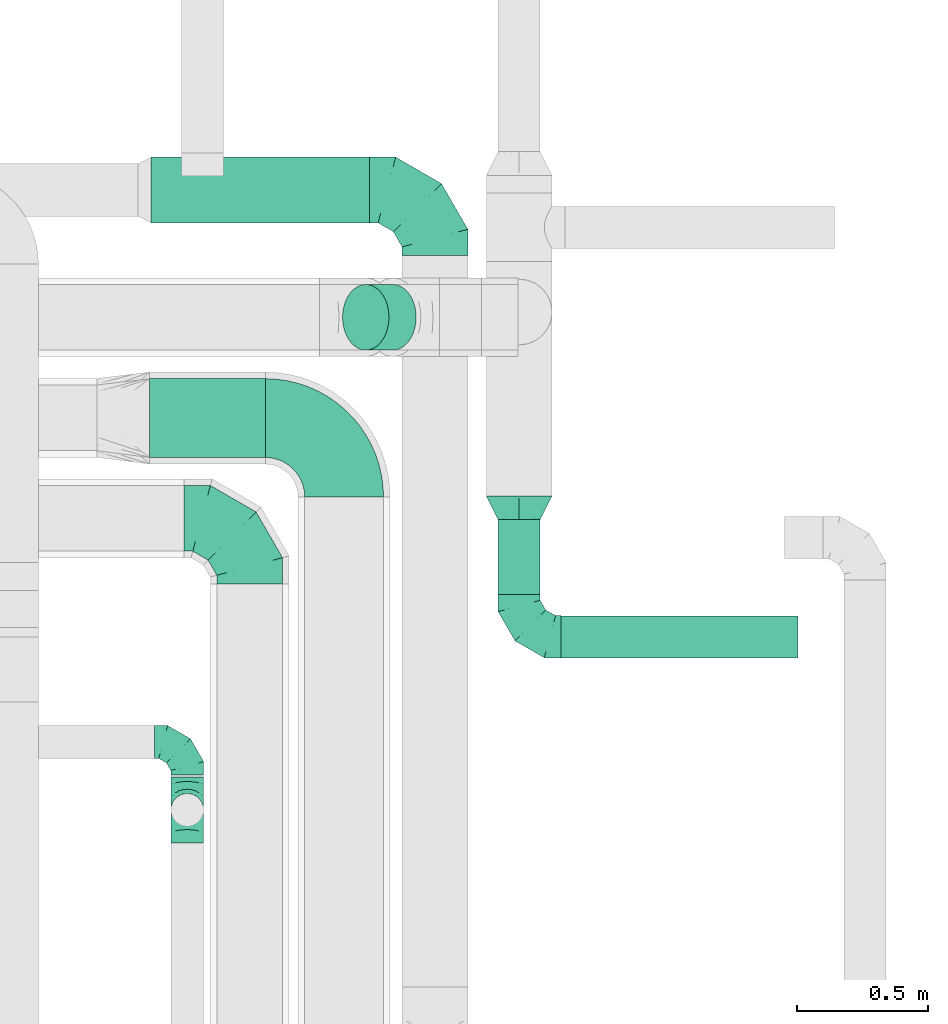
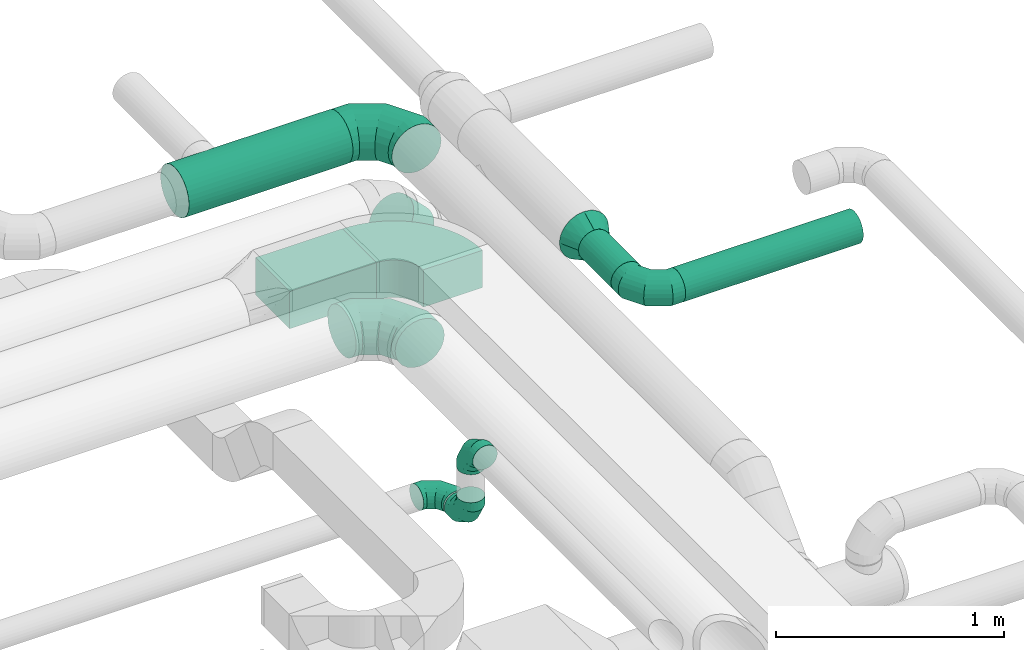
# One storey, part 73 of 92: 8 flow fittings, 5 flow segments.
"""IFC2X3 building model written with IfcOpenShell, lengths in millimetres."""

from ifc_helpers import new_model, entity, si_unit, converted_unit, derived_unit, direction, frame, frame_2d, origin, origin_2d_with_axis, place, context, subcontext, project, spatial, polyline, circle_curve, parameter, trimmed, segment, composite_curve, rectangle, circle, outline, extrude, faceted_brep, source, transform, mapped, material, type_object, type_shapes, element, save


model = new_model("IFC2X3")

# Units and contexts
model_context = context("Model", 3, precision=0.01, world=origin(), true_north=direction((6.12303176911189e-17, 1.0)))
body_context = subcontext(model_context, "Body", "Model", "MODEL_VIEW")
ifc_project = project(units=[si_unit("LENGTHUNIT", "METRE", prefix="MILLI"), si_unit("AREAUNIT", "SQUARE_METRE"), si_unit("VOLUMEUNIT", "CUBIC_METRE"), converted_unit("PLANEANGLEUNIT", "DEGREE", entity("IfcRatioMeasure", 0.0174532925199433), si_unit("PLANEANGLEUNIT", "RADIAN"), dimensions=[0, 0, 0, 0, 0, 0, 0]), si_unit("MASSUNIT", "GRAM", prefix="KILO"), derived_unit("MASSDENSITYUNIT", [(si_unit("MASSUNIT", "GRAM", prefix="KILO"), 1), (si_unit("LENGTHUNIT", "METRE"), -3)]), derived_unit("MOMENTOFINERTIAUNIT", [(si_unit("LENGTHUNIT", "METRE"), 4)]), si_unit("TIMEUNIT", "SECOND"), si_unit("FREQUENCYUNIT", "HERTZ"), si_unit("THERMODYNAMICTEMPERATUREUNIT", "DEGREE_CELSIUS"), derived_unit("THERMALTRANSMITTANCEUNIT", [(si_unit("MASSUNIT", "GRAM", prefix="KILO"), 1), (si_unit("THERMODYNAMICTEMPERATUREUNIT", "KELVIN"), -1), (si_unit("TIMEUNIT", "SECOND"), -3)]), derived_unit("VOLUMETRICFLOWRATEUNIT", [(si_unit("LENGTHUNIT", "METRE"), 3), (si_unit("TIMEUNIT", "SECOND"), -1)]), derived_unit("MASSFLOWRATEUNIT", [(si_unit("MASSUNIT", "GRAM", prefix="KILO"), 1), (si_unit("TIMEUNIT", "SECOND"), -1)]), derived_unit("ROTATIONALFREQUENCYUNIT", [(si_unit("TIMEUNIT", "SECOND"), -1)]), si_unit("ELECTRICCURRENTUNIT", "AMPERE"), si_unit("ELECTRICVOLTAGEUNIT", "VOLT"), si_unit("POWERUNIT", "WATT"), si_unit("FORCEUNIT", "NEWTON", prefix="KILO"), si_unit("ILLUMINANCEUNIT", "LUX"), si_unit("LUMINOUSFLUXUNIT", "LUMEN"), si_unit("LUMINOUSINTENSITYUNIT", "CANDELA"), derived_unit("USERDEFINED", [(si_unit("MASSUNIT", "GRAM", prefix="KILO"), -1), (si_unit("LENGTHUNIT", "METRE"), -2), (si_unit("TIMEUNIT", "SECOND"), 3), (si_unit("LUMINOUSFLUXUNIT", "LUMEN"), 1)]), derived_unit("LINEARVELOCITYUNIT", [(si_unit("LENGTHUNIT", "METRE"), 1), (si_unit("TIMEUNIT", "SECOND"), -1)]), si_unit("PRESSUREUNIT", "PASCAL"), derived_unit("USERDEFINED", [(si_unit("LENGTHUNIT", "METRE"), -2), (si_unit("MASSUNIT", "GRAM", prefix="KILO"), 1), (si_unit("TIMEUNIT", "SECOND"), -2)]), derived_unit("LINEARFORCEUNIT", [(si_unit("MASSUNIT", "GRAM", prefix="KILO"), 1), (si_unit("LENGTHUNIT", "METRE"), 1), (si_unit("TIMEUNIT", "SECOND"), -2), (si_unit("LENGTHUNIT", "METRE"), -1)]), derived_unit("PLANARFORCEUNIT", [(si_unit("MASSUNIT", "GRAM", prefix="KILO"), 1), (si_unit("LENGTHUNIT", "METRE"), 1), (si_unit("TIMEUNIT", "SECOND"), -2), (si_unit("LENGTHUNIT", "METRE"), -2)])], contexts=[model_context])

# Site, building, storey
site_placement = place(None, origin())
site = spatial("IfcSite", under=ifc_project, at=site_placement, CompositionType="ELEMENT")
building_placement = place(site_placement, origin())
building = spatial("IfcBuilding", under=site, at=building_placement, CompositionType="ELEMENT")
storey_placement = place(building_placement, frame((0.0, 0.0, 4200.0)))
storey = spatial("IfcBuildingStorey", under=building, at=storey_placement, CompositionType="ELEMENT", Elevation=4200.0)

# Flow segments
duct_segment_type_1 = type_object("IfcDuctSegmentType", PredefinedType="NOTDEFINED")
flow_segment_1_placement = place(storey_placement, frame((60704.33, 15188.51, 3200.0)))
element("IfcFlowSegment", 1, at=flow_segment_1_placement, inside=storey, type_object=duct_segment_type_1, context=body_context, shape_type="SweptSolid", body=[
    extrude(rectangle(XDim=440.000000000013, YDim=300.000000000001, at=origin_2d_with_axis()), frame((220.0, 150.0, 0.0), z_axis=(0.0, 0.0, 1.0), x_axis=(-1.0, 0.0, 0.0)), (0.0, 0.0, 1.0), 200.0),
])
duct_segment_type_2 = type_object("IfcDuctSegmentType", PredefinedType="NOTDEFINED")
flow_segment_2_placement = place(storey_placement, frame((60710.0, 16079.62, 3193.4)))
element("IfcFlowSegment", 2, at=flow_segment_2_placement, inside=storey, type_object=duct_segment_type_2, context=body_context, shape_type="SweptSolid", body=[
    extrude(circle(Radius=125.0, at=origin_2d_with_axis()), frame((0.0, 126.6, 126.6), z_axis=(1.0, 0.0, 0.0), x_axis=(0.0, 1.0, 0.0)), (0.0, 0.0, 1.0), 830.000000000071),
])
flow_segment_3_placement = place(storey_placement, frame((61436.58, 15595.41, 2983.24)))
element("IfcFlowSegment", 3, at=flow_segment_3_placement, inside=storey, type_object=duct_segment_type_2, context=body_context, shape_type="SweptSolid", body=[
    extrude(circle(Radius=125.0, at=origin_2d_with_axis()), frame((193.54, 126.6, 89.98), z_axis=(-0.707106445676234, 0.0, 0.707107116696702), x_axis=(0.0, -1.0, 0.0)), (0.0, 0.0, 1.0), 146.446302678895),
])
duct_segment_type_3 = type_object("IfcDuctSegmentType", PredefinedType="NOTDEFINED")
flow_segment_4_placement = place(storey_placement, frame((62028.4, 14666.74, 3218.4)))
element("IfcFlowSegment", 4, at=flow_segment_4_placement, inside=storey, type_object=duct_segment_type_3, context=body_context, shape_type="SweptSolid", body=[
    extrude(circle(Radius=80.0, at=origin_2d_with_axis()), frame((81.6, 0.0, 81.6), z_axis=(0.0, 1.0, 0.0), x_axis=(1.0, 0.0, 0.0)), (0.0, 0.0, 1.0), 285.234298504728),
])
flow_segment_5_placement = place(storey_placement, frame((62270.0, 14425.15, 3218.4)))
element("IfcFlowSegment", 5, at=flow_segment_5_placement, inside=storey, type_object=duct_segment_type_3, context=body_context, shape_type="SweptSolid", body=[
    extrude(circle(Radius=80.0, at=origin_2d_with_axis()), frame((0.0, 81.6, 81.6), z_axis=(1.0, 0.0, 0.0), x_axis=(0.0, -1.0, 0.0)), (0.0, 0.0, 1.0), 900.000000000012),
])

# Flow fittings
ifc_material = material()
duct_fitting_type_1 = type_object("IfcDuctFittingType", PredefinedType="NOTDEFINED", material=ifc_material)
shared_shape_1 = source(origin(), body_context, "Body", "Brep", [
    faceted_brep([(-160.0, 0.0, -80.0), (-160.0, -20.71, -77.27), (-160.0, -40.0, -69.28), (-160.0, -56.57, -56.57), (-160.0, -69.28, -40.0), (-160.0, -77.27, -20.71), (-160.0, -80.0, 0.0), (-160.0, -77.27, 20.71), (-160.0, -69.28, 40.0), (-160.0, -56.57, 56.57), (-160.0, -40.0, 69.28), (-160.0, -20.71, 77.27), (-160.0, 0.0, 80.0), (-160.0, 20.71, 77.27), (-160.0, 40.0, 69.28), (-160.0, 56.57, 56.57), (-160.0, 69.28, 40.0), (-160.0, 77.27, 20.71), (-160.0, 80.0, 0.0), (-160.0, 77.27, -20.71), (-160.0, 69.28, -40.0), (-160.0, 56.57, -56.57), (-160.0, 40.0, -69.28), (-160.0, 20.71, -77.27), (-122.68, 20.71, 77.27), (-127.85, 40.0, 69.28), (-117.13, 0.0, 80.0), (-132.29, 56.57, 56.57), (-137.83, 77.27, 20.71), (-138.56, 80.0, 0.0), (-135.69, 69.28, 40.0), (-135.69, 69.28, -40.0), (-132.29, 56.57, -56.57), (-137.83, 77.27, -20.71), (-122.68, 20.71, -77.27), (-117.13, 0.0, -80.0), (-127.85, 40.0, -69.28), (-111.58, -20.71, -77.27), (-106.41, -40.0, -69.28), (-101.97, -56.57, -56.57), (-98.56, -69.28, -40.0), (-96.42, -77.27, -20.71), (-95.69, -80.0, 0.0), (-96.42, -77.27, 20.71), (-98.56, -69.28, 40.0), (-101.97, -56.57, 56.57), (-106.41, -40.0, 69.28), (-111.58, -20.71, 77.27), (-58.03, 58.03, 77.27), (-72.15, 72.15, 69.28), (-42.87, 42.87, 80.0), (-84.28, 84.28, 56.57), (-93.59, 93.59, 40.0), (-99.44, 99.44, 20.71), (-101.44, 101.44, 0.0), (-99.44, 99.44, -20.71), (-93.59, 93.59, -40.0), (-84.28, 84.28, -56.57), (-58.03, 58.03, -77.27), (-42.87, 42.87, -80.0), (-72.15, 72.15, -69.28), (-27.71, 27.71, -77.27), (-13.59, 13.59, -69.28), (-1.46, 1.46, -56.57), (7.85, -7.85, -40.0), (13.7, -13.7, -20.71), (15.69, -15.69, 0.0), (13.7, -13.7, 20.71), (7.85, -7.85, 40.0), (-1.46, 1.46, 56.57), (-13.59, 13.59, 69.28), (-27.71, 27.71, 77.27), (-20.71, 122.68, 77.27), (-40.0, 127.85, 69.28), (0.0, 117.13, 80.0), (-56.57, 132.29, 56.57), (-69.28, 135.69, 40.0), (-77.27, 137.83, 20.71), (-80.0, 138.56, 0.0), (-77.27, 137.83, -20.71), (-69.28, 135.69, -40.0), (-56.57, 132.29, -56.57), (-20.71, 122.68, -77.27), (0.0, 117.13, -80.0), (-40.0, 127.85, -69.28), (20.71, 111.58, -77.27), (40.0, 106.41, -69.28), (56.57, 101.97, -56.57), (69.28, 98.56, -40.0), (77.27, 96.42, -20.71), (80.0, 95.69, 0.0), (77.27, 96.42, 20.71), (69.28, 98.56, 40.0), (56.57, 101.97, 56.57), (40.0, 106.41, 69.28), (20.71, 111.58, 77.27), (-20.71, 160.0, -77.27), (-40.0, 160.0, -69.28), (-56.57, 160.0, -56.57), (-69.28, 160.0, -40.0), (-77.27, 160.0, -20.71), (-80.0, 160.0, 0.0), (-77.27, 160.0, 20.71), (-69.28, 160.0, 40.0), (-56.57, 160.0, 56.57), (-40.0, 160.0, 69.28), (-20.71, 160.0, 77.27), (0.0, 160.0, 80.0), (20.71, 160.0, 77.27), (40.0, 160.0, 69.28), (56.57, 160.0, 56.57), (69.28, 160.0, 40.0), (77.27, 160.0, 20.71), (80.0, 160.0, 0.0), (77.27, 160.0, -20.71), (69.28, 160.0, -40.0), (56.57, 160.0, -56.57), (40.0, 160.0, -69.28), (20.71, 160.0, -77.27), (0.0, 160.0, -80.0)], [[[0, 1, 2, 3, 4, 5, 6, 7, 8, 9, 10, 11, 12, 13, 14, 15, 16, 17, 18, 19, 20, 21, 22, 23]], [[24, 25, 14, 13]], [[26, 24, 13, 12]], [[14, 25, 27, 15]], [[28, 29, 18, 17]], [[30, 28, 17, 16]], [[15, 27, 30, 16]], [[20, 31, 32, 21]], [[33, 31, 20, 19]], [[18, 29, 33, 19]], [[34, 35, 0, 23]], [[36, 34, 23, 22]], [[32, 36, 22, 21]], [[1, 0, 35, 37]], [[2, 1, 37, 38]], [[3, 2, 38, 39]], [[5, 4, 40, 41]], [[6, 5, 41, 42]], [[39, 40, 4, 3]], [[6, 42, 43, 7]], [[7, 43, 44, 8]], [[8, 44, 45, 9]], [[9, 45, 46, 10]], [[10, 46, 47, 11]], [[26, 12, 11, 47]], [[48, 49, 25, 24]], [[50, 48, 24, 26]], [[27, 25, 49, 51]], [[52, 53, 28, 30]], [[51, 52, 30, 27]], [[29, 28, 53, 54]], [[55, 56, 31, 33]], [[54, 55, 33, 29]], [[32, 31, 56, 57]], [[58, 59, 35, 34]], [[60, 58, 34, 36]], [[57, 60, 36, 32]], [[37, 35, 59, 61]], [[38, 37, 61, 62]], [[39, 38, 62, 63]], [[41, 40, 64, 65]], [[42, 41, 65, 66]], [[63, 64, 40, 39]], [[43, 42, 66, 67]], [[44, 43, 67, 68]], [[68, 69, 45, 44]], [[46, 45, 69, 70]], [[47, 46, 70, 71]], [[26, 47, 71, 50]], [[72, 73, 49, 48]], [[74, 72, 48, 50]], [[51, 49, 73, 75]], [[76, 77, 53, 52]], [[75, 76, 52, 51]], [[54, 53, 77, 78]], [[79, 80, 56, 55]], [[78, 79, 55, 54]], [[57, 56, 80, 81]], [[82, 83, 59, 58]], [[84, 82, 58, 60]], [[81, 84, 60, 57]], [[61, 59, 83, 85]], [[62, 61, 85, 86]], [[63, 62, 86, 87]], [[65, 64, 88, 89]], [[66, 65, 89, 90]], [[87, 88, 64, 63]], [[67, 66, 90, 91]], [[68, 67, 91, 92]], [[92, 93, 69, 68]], [[70, 69, 93, 94]], [[71, 70, 94, 95]], [[50, 71, 95, 74]], [[96, 97, 98, 99, 100, 101, 102, 103, 104, 105, 106, 107, 108, 109, 110, 111, 112, 113, 114, 115, 116, 117, 118, 119]], [[72, 74, 107, 106]], [[73, 72, 106, 105]], [[75, 73, 105, 104]], [[77, 76, 103, 102]], [[78, 77, 102, 101]], [[75, 104, 103, 76]], [[78, 101, 100, 79]], [[79, 100, 99, 80]], [[80, 99, 98, 81]], [[84, 97, 96, 82]], [[82, 96, 119, 83]], [[84, 81, 98, 97]], [[118, 117, 86, 85]], [[119, 118, 85, 83]], [[116, 87, 86, 117]], [[88, 115, 114, 89]], [[89, 114, 113, 90]], [[115, 88, 87, 116]], [[112, 111, 92, 91]], [[113, 112, 91, 90]], [[111, 110, 93, 92]], [[95, 94, 109, 108]], [[74, 95, 108, 107]], [[110, 109, 94, 93]]]),
])
type_shapes(duct_fitting_type_1, [shared_shape_1])
flow_fitting_1_placement = place(storey_placement, frame((62110.0, 14506.74, 3300.0), z_axis=(0.0, 0.0, 1.0), x_axis=(0.0, -1.0, 0.0)))
element("IfcFlowFitting", 6, at=flow_fitting_1_placement, inside=storey, type_object=duct_fitting_type_1, material=ifc_material, context=body_context, shape_type="MappedRepresentation", body=[
    mapped(shared_shape_1, transform((0.0, 0.0, 0.0), scale=1.0)),
])
duct_fitting_type_2 = type_object("IfcDuctFittingType", PredefinedType="NOTDEFINED", material=ifc_material)
shared_shape_2 = source(origin(), body_context, "Body", "Brep", [
    faceted_brep([(-250.0, 0.0, -125.0), (-250.0, -32.35, -120.74), (-250.0, -62.5, -108.25), (-250.0, -88.39, -88.39), (-250.0, -108.25, -62.5), (-250.0, -120.74, -32.35), (-250.0, -125.0, 0.0), (-250.0, -120.74, 32.35), (-250.0, -108.25, 62.5), (-250.0, -88.39, 88.39), (-250.0, -62.5, 108.25), (-250.0, -32.35, 120.74), (-250.0, 0.0, 125.0), (-250.0, 32.35, 120.74), (-250.0, 62.5, 108.25), (-250.0, 88.39, 88.39), (-250.0, 108.25, 62.5), (-250.0, 120.74, 32.35), (-250.0, 125.0, 0.0), (-250.0, 120.74, -32.35), (-250.0, 108.25, -62.5), (-250.0, 88.39, -88.39), (-250.0, 62.5, -108.25), (-250.0, 32.35, -120.74), (-191.68, 32.35, 120.74), (-199.76, 62.5, 108.25), (-183.01, 0.0, 125.0), (-206.7, 88.39, 88.39), (-215.37, 120.74, 32.35), (-216.51, 125.0, 0.0), (-212.02, 108.25, 62.5), (-212.02, 108.25, -62.5), (-206.7, 88.39, -88.39), (-215.37, 120.74, -32.35), (-191.68, 32.35, -120.74), (-183.01, 0.0, -125.0), (-199.76, 62.5, -108.25), (-174.34, -32.35, -120.74), (-166.27, -62.5, -108.25), (-159.33, -88.39, -88.39), (-154.01, -108.25, -62.5), (-150.66, -120.74, -32.35), (-149.52, -125.0, 0.0), (-150.66, -120.74, 32.35), (-154.01, -108.25, 62.5), (-159.33, -88.39, 88.39), (-166.27, -62.5, 108.25), (-174.34, -32.35, 120.74), (-90.67, 90.67, 120.74), (-112.74, 112.74, 108.25), (-66.99, 66.99, 125.0), (-131.69, 131.69, 88.39), (-146.23, 146.23, 62.5), (-155.38, 155.38, 32.35), (-158.49, 158.49, 0.0), (-155.38, 155.38, -32.35), (-146.23, 146.23, -62.5), (-131.69, 131.69, -88.39), (-90.67, 90.67, -120.74), (-66.99, 66.99, -125.0), (-112.74, 112.74, -108.25), (-43.3, 43.3, -120.74), (-21.23, 21.23, -108.25), (-2.28, 2.28, -88.39), (12.26, -12.26, -62.5), (21.4, -21.4, -32.35), (24.52, -24.52, 0.0), (21.4, -21.4, 32.35), (12.26, -12.26, 62.5), (-2.28, 2.28, 88.39), (-21.23, 21.23, 108.25), (-43.3, 43.3, 120.74), (-32.35, 191.68, 120.74), (-62.5, 199.76, 108.25), (0.0, 183.01, 125.0), (-88.39, 206.7, 88.39), (-108.25, 212.02, 62.5), (-120.74, 215.37, 32.35), (-125.0, 216.51, 0.0), (-120.74, 215.37, -32.35), (-108.25, 212.02, -62.5), (-88.39, 206.7, -88.39), (-32.35, 191.68, -120.74), (0.0, 183.01, -125.0), (-62.5, 199.76, -108.25), (32.35, 174.34, -120.74), (62.5, 166.27, -108.25), (88.39, 159.33, -88.39), (108.25, 154.01, -62.5), (120.74, 150.66, -32.35), (125.0, 149.52, 0.0), (120.74, 150.66, 32.35), (108.25, 154.01, 62.5), (88.39, 159.33, 88.39), (62.5, 166.27, 108.25), (32.35, 174.34, 120.74), (-32.35, 250.0, -120.74), (-62.5, 250.0, -108.25), (-88.39, 250.0, -88.39), (-108.25, 250.0, -62.5), (-120.74, 250.0, -32.35), (-125.0, 250.0, 0.0), (-120.74, 250.0, 32.35), (-108.25, 250.0, 62.5), (-88.39, 250.0, 88.39), (-62.5, 250.0, 108.25), (-32.35, 250.0, 120.74), (0.0, 250.0, 125.0), (32.35, 250.0, 120.74), (62.5, 250.0, 108.25), (88.39, 250.0, 88.39), (108.25, 250.0, 62.5), (120.74, 250.0, 32.35), (125.0, 250.0, 0.0), (120.74, 250.0, -32.35), (108.25, 250.0, -62.5), (88.39, 250.0, -88.39), (62.5, 250.0, -108.25), (32.35, 250.0, -120.74), (0.0, 250.0, -125.0)], [[[0, 1, 2, 3, 4, 5, 6, 7, 8, 9, 10, 11, 12, 13, 14, 15, 16, 17, 18, 19, 20, 21, 22, 23]], [[24, 25, 14, 13]], [[26, 24, 13, 12]], [[14, 25, 27, 15]], [[28, 29, 18, 17]], [[30, 28, 17, 16]], [[15, 27, 30, 16]], [[20, 31, 32, 21]], [[33, 31, 20, 19]], [[18, 29, 33, 19]], [[34, 35, 0, 23]], [[36, 34, 23, 22]], [[21, 32, 36, 22]], [[1, 0, 35, 37]], [[2, 1, 37, 38]], [[38, 39, 3, 2]], [[5, 4, 40, 41]], [[6, 5, 41, 42]], [[39, 40, 4, 3]], [[6, 42, 43, 7]], [[7, 43, 44, 8]], [[8, 44, 45, 9]], [[9, 45, 46, 10]], [[10, 46, 47, 11]], [[26, 12, 11, 47]], [[48, 49, 25, 24]], [[50, 48, 24, 26]], [[27, 25, 49, 51]], [[52, 53, 28, 30]], [[51, 52, 30, 27]], [[29, 28, 53, 54]], [[55, 56, 31, 33]], [[54, 55, 33, 29]], [[32, 31, 56, 57]], [[58, 59, 35, 34]], [[60, 58, 34, 36]], [[57, 60, 36, 32]], [[37, 35, 59, 61]], [[38, 37, 61, 62]], [[39, 38, 62, 63]], [[41, 40, 64, 65]], [[42, 41, 65, 66]], [[63, 64, 40, 39]], [[43, 42, 66, 67]], [[44, 43, 67, 68]], [[68, 69, 45, 44]], [[46, 45, 69, 70]], [[47, 46, 70, 71]], [[26, 47, 71, 50]], [[72, 73, 49, 48]], [[74, 72, 48, 50]], [[51, 49, 73, 75]], [[76, 77, 53, 52]], [[75, 76, 52, 51]], [[54, 53, 77, 78]], [[79, 80, 56, 55]], [[78, 79, 55, 54]], [[57, 56, 80, 81]], [[82, 83, 59, 58]], [[84, 82, 58, 60]], [[81, 84, 60, 57]], [[61, 59, 83, 85]], [[62, 61, 85, 86]], [[63, 62, 86, 87]], [[65, 64, 88, 89]], [[66, 65, 89, 90]], [[87, 88, 64, 63]], [[67, 66, 90, 91]], [[68, 67, 91, 92]], [[92, 93, 69, 68]], [[70, 69, 93, 94]], [[71, 70, 94, 95]], [[50, 71, 95, 74]], [[96, 97, 98, 99, 100, 101, 102, 103, 104, 105, 106, 107, 108, 109, 110, 111, 112, 113, 114, 115, 116, 117, 118, 119]], [[72, 74, 107, 106]], [[73, 72, 106, 105]], [[75, 73, 105, 104]], [[77, 76, 103, 102]], [[78, 77, 102, 101]], [[75, 104, 103, 76]], [[78, 101, 100, 79]], [[79, 100, 99, 80]], [[80, 99, 98, 81]], [[84, 97, 96, 82]], [[82, 96, 119, 83]], [[84, 81, 98, 97]], [[83, 119, 118, 85]], [[85, 118, 117, 86]], [[116, 87, 86, 117]], [[88, 115, 114, 89]], [[89, 114, 113, 90]], [[115, 88, 87, 116]], [[91, 90, 113, 112]], [[92, 91, 112, 111]], [[111, 110, 93, 92]], [[95, 94, 109, 108]], [[74, 95, 108, 107]], [[110, 109, 94, 93]]]),
])
type_shapes(duct_fitting_type_2, [shared_shape_2])
for number, where, z_axis, x_axis in (
    (7, (61790.0, 16206.22, 3320.0), (0.0, 0.0, 1.0), (0.0, 1.0, 0.0)),
    (8, (61085.0, 14957.0, 3282.5), (0.0, 0.0, 1.0), (0.0, 1.0, 0.0)),
):
    element("IfcFlowFitting", number, at=place(storey_placement, frame(where, z_axis=z_axis, x_axis=x_axis)), inside=storey, type_object=duct_fitting_type_2, material=ifc_material, context=body_context, shape_type="MappedRepresentation", body=[
        mapped(shared_shape_2, transform((0.0, 0.0, 0.0), scale=1.0)),
    ])
duct_fitting_type_3 = type_object("IfcDuctFittingType", PredefinedType="NOTDEFINED", material=ifc_material)
shared_shape_3 = source(origin(), body_context, "Body", "Brep", [
    faceted_brep([(-125.0, 0.0, -62.5), (-125.0, -16.18, -60.37), (-125.0, -31.25, -54.13), (-125.0, -44.19, -44.19), (-125.0, -54.13, -31.25), (-125.0, -60.37, -16.18), (-125.0, -62.5, 0.0), (-125.0, -60.37, 16.18), (-125.0, -54.13, 31.25), (-125.0, -44.19, 44.19), (-125.0, -31.25, 54.13), (-125.0, -16.18, 60.37), (-125.0, 0.0, 62.5), (-125.0, 16.18, 60.37), (-125.0, 31.25, 54.13), (-125.0, 44.19, 44.19), (-125.0, 54.13, 31.25), (-125.0, 60.37, 16.18), (-125.0, 62.5, 0.0), (-125.0, 60.37, -16.18), (-125.0, 54.13, -31.25), (-125.0, 44.19, -44.19), (-125.0, 31.25, -54.13), (-125.0, 16.18, -60.37), (-95.84, 16.18, 60.37), (-99.88, 31.25, 54.13), (-91.51, 0.0, 62.5), (-103.35, 44.19, 44.19), (-107.68, 60.37, 16.18), (-108.25, 62.5, 0.0), (-106.01, 54.13, 31.25), (-106.01, 54.13, -31.25), (-103.35, 44.19, -44.19), (-107.68, 60.37, -16.18), (-95.84, 16.18, -60.37), (-91.51, 0.0, -62.5), (-99.88, 31.25, -54.13), (-87.17, -16.18, -60.37), (-83.13, -31.25, -54.13), (-79.66, -44.19, -44.19), (-77.0, -54.13, -31.25), (-75.33, -60.37, -16.18), (-74.76, -62.5, 0.0), (-75.33, -60.37, 16.18), (-77.0, -54.13, 31.25), (-79.66, -44.19, 44.19), (-83.13, -31.25, 54.13), (-87.17, -16.18, 60.37), (-45.34, 45.34, 60.37), (-56.37, 56.37, 54.13), (-33.49, 33.49, 62.5), (-65.85, 65.85, 44.19), (-73.12, 73.12, 31.25), (-77.69, 77.69, 16.18), (-79.25, 79.25, 0.0), (-77.69, 77.69, -16.18), (-73.12, 73.12, -31.25), (-65.85, 65.85, -44.19), (-45.34, 45.34, -60.37), (-33.49, 33.49, -62.5), (-56.37, 56.37, -54.13), (-21.65, 21.65, -60.37), (-10.62, 10.62, -54.13), (-1.14, 1.14, -44.19), (6.13, -6.13, -31.25), (10.7, -10.7, -16.18), (12.26, -12.26, 0.0), (10.7, -10.7, 16.18), (6.13, -6.13, 31.25), (-1.14, 1.14, 44.19), (-10.62, 10.62, 54.13), (-21.65, 21.65, 60.37), (-16.18, 95.84, 60.37), (-31.25, 99.88, 54.13), (0.0, 91.51, 62.5), (-44.19, 103.35, 44.19), (-54.13, 106.01, 31.25), (-60.37, 107.68, 16.18), (-62.5, 108.25, 0.0), (-60.37, 107.68, -16.18), (-54.13, 106.01, -31.25), (-44.19, 103.35, -44.19), (-16.18, 95.84, -60.37), (0.0, 91.51, -62.5), (-31.25, 99.88, -54.13), (16.18, 87.17, -60.37), (31.25, 83.13, -54.13), (44.19, 79.66, -44.19), (54.13, 77.0, -31.25), (60.37, 75.33, -16.18), (62.5, 74.76, 0.0), (60.37, 75.33, 16.18), (54.13, 77.0, 31.25), (44.19, 79.66, 44.19), (31.25, 83.13, 54.13), (16.18, 87.17, 60.37), (-16.18, 125.0, -60.37), (-31.25, 125.0, -54.13), (-44.19, 125.0, -44.19), (-54.13, 125.0, -31.25), (-60.37, 125.0, -16.18), (-62.5, 125.0, 0.0), (-60.37, 125.0, 16.18), (-54.13, 125.0, 31.25), (-44.19, 125.0, 44.19), (-31.25, 125.0, 54.13), (-16.18, 125.0, 60.37), (0.0, 125.0, 62.5), (16.18, 125.0, 60.37), (31.25, 125.0, 54.13), (44.19, 125.0, 44.19), (54.13, 125.0, 31.25), (60.37, 125.0, 16.18), (62.5, 125.0, 0.0), (60.37, 125.0, -16.18), (54.13, 125.0, -31.25), (44.19, 125.0, -44.19), (31.25, 125.0, -54.13), (16.18, 125.0, -60.37), (0.0, 125.0, -62.5)], [[[0, 1, 2, 3, 4, 5, 6, 7, 8, 9, 10, 11, 12, 13, 14, 15, 16, 17, 18, 19, 20, 21, 22, 23]], [[24, 25, 14, 13]], [[26, 24, 13, 12]], [[14, 25, 27, 15]], [[28, 29, 18, 17]], [[30, 28, 17, 16]], [[15, 27, 30, 16]], [[20, 31, 32, 21]], [[33, 31, 20, 19]], [[18, 29, 33, 19]], [[34, 35, 0, 23]], [[36, 34, 23, 22]], [[21, 32, 36, 22]], [[1, 0, 35, 37]], [[2, 1, 37, 38]], [[38, 39, 3, 2]], [[5, 4, 40, 41]], [[6, 5, 41, 42]], [[39, 40, 4, 3]], [[6, 42, 43, 7]], [[7, 43, 44, 8]], [[45, 9, 8, 44]], [[9, 45, 46, 10]], [[10, 46, 47, 11]], [[26, 12, 11, 47]], [[48, 49, 25, 24]], [[50, 48, 24, 26]], [[27, 25, 49, 51]], [[52, 53, 28, 30]], [[51, 52, 30, 27]], [[29, 28, 53, 54]], [[55, 56, 31, 33]], [[54, 55, 33, 29]], [[57, 32, 31, 56]], [[58, 59, 35, 34]], [[60, 58, 34, 36]], [[57, 60, 36, 32]], [[37, 35, 59, 61]], [[38, 37, 61, 62]], [[39, 38, 62, 63]], [[41, 40, 64, 65]], [[42, 41, 65, 66]], [[63, 64, 40, 39]], [[43, 42, 66, 67]], [[44, 43, 67, 68]], [[68, 69, 45, 44]], [[46, 45, 69, 70]], [[47, 46, 70, 71]], [[26, 47, 71, 50]], [[72, 73, 49, 48]], [[74, 72, 48, 50]], [[51, 49, 73, 75]], [[76, 77, 53, 52]], [[75, 76, 52, 51]], [[54, 53, 77, 78]], [[79, 80, 56, 55]], [[78, 79, 55, 54]], [[81, 57, 56, 80]], [[82, 83, 59, 58]], [[84, 82, 58, 60]], [[81, 84, 60, 57]], [[61, 59, 83, 85]], [[62, 61, 85, 86]], [[63, 62, 86, 87]], [[65, 64, 88, 89]], [[66, 65, 89, 90]], [[87, 88, 64, 63]], [[67, 66, 90, 91]], [[68, 67, 91, 92]], [[92, 93, 69, 68]], [[70, 69, 93, 94]], [[71, 70, 94, 95]], [[50, 71, 95, 74]], [[96, 97, 98, 99, 100, 101, 102, 103, 104, 105, 106, 107, 108, 109, 110, 111, 112, 113, 114, 115, 116, 117, 118, 119]], [[72, 74, 107, 106]], [[73, 72, 106, 105]], [[75, 73, 105, 104]], [[77, 76, 103, 102]], [[78, 77, 102, 101]], [[75, 104, 103, 76]], [[78, 101, 100, 79]], [[79, 100, 99, 80]], [[80, 99, 98, 81]], [[96, 119, 83, 82]], [[97, 96, 82, 84]], [[84, 81, 98, 97]], [[83, 119, 118, 85]], [[85, 118, 117, 86]], [[116, 87, 86, 117]], [[88, 115, 114, 89]], [[89, 114, 113, 90]], [[115, 88, 87, 116]], [[91, 90, 113, 112]], [[92, 91, 112, 111]], [[111, 110, 93, 92]], [[95, 94, 109, 108]], [[74, 95, 108, 107]], [[110, 109, 94, 93]]]),
])
type_shapes(duct_fitting_type_3, [shared_shape_3])
for number, where, z_axis, x_axis in (
    (9, (60847.39, 13847.55, 3350.0), (-1.0, 0.0, 0.0), (0.0, 1.0, 0.0)),
    (10, (60847.39, 13847.55, 2950.0), (1.0, 0.0, 0.0), (0.0, 0.0, -1.0)),
    (11, (60847.39, 14106.28, 2950.0), (0.0, 0.0, 1.0), (0.0, 1.0, 0.0)),
):
    element("IfcFlowFitting", number, at=place(storey_placement, frame(where, z_axis=z_axis, x_axis=x_axis)), inside=storey, type_object=duct_fitting_type_3, material=ifc_material, context=body_context, shape_type="MappedRepresentation", body=[
        mapped(shared_shape_3, transform((0.0, 0.0, 0.0), scale=1.0)),
    ])
duct_fitting_type_4 = type_object("IfcDuctFittingType", PredefinedType="NOTDEFINED", material=ifc_material)
shared_shape_4 = source(origin(), body_context, "Body", "Brep", [
    faceted_brep([(90.0, -73.47, -101.13), (90.0, -38.63, -118.88), (90.0, 0.0, -125.0), (90.0, 38.63, -118.88), (90.0, 73.47, -101.13), (90.0, 101.13, -73.47), (90.0, 118.88, -38.63), (90.0, 125.0, 0.0), (90.0, 118.88, 38.63), (90.0, 101.13, 73.47), (90.0, 73.47, 101.13), (90.0, 38.63, 118.88), (90.0, 0.0, 125.0), (90.0, -38.63, 118.88), (90.0, -73.47, 101.13), (90.0, -101.13, 73.47), (90.0, -118.88, 38.63), (90.0, -125.0, 0.0), (90.0, -118.88, -38.63), (90.0, -101.13, -73.47), (0.0, -30.61, -73.91), (0.0, -43.59, -65.24), (0.0, -56.57, -56.57), (0.0, -65.24, -43.59), (0.0, -73.91, -30.61), (0.0, -76.96, -15.31), (0.0, -80.0, 0.0), (0.0, -76.96, 15.31), (0.0, -73.91, 30.61), (0.0, -65.24, 43.59), (0.0, -56.57, 56.57), (0.0, -43.59, 65.24), (0.0, -30.61, 73.91), (0.0, -15.31, 76.96), (0.0, 0.0, 80.0), (0.0, 15.31, 76.96), (0.0, 30.61, 73.91), (0.0, 43.59, 65.24), (0.0, 56.57, 56.57), (0.0, 65.24, 43.59), (0.0, 73.91, 30.61), (0.0, 76.96, 15.31), (0.0, 80.0, 0.0), (0.0, 76.96, -15.31), (0.0, 73.91, -30.61), (0.0, 65.24, -43.59), (0.0, 56.57, -56.57), (0.0, 43.59, -65.24), (0.0, 30.61, -73.91), (0.0, 15.31, -76.96), (0.0, 0.0, -80.0), (0.0, -15.31, -76.96)], [[[0, 1, 2, 3, 4, 5, 6, 7, 8, 9, 10, 11, 12, 13, 14, 15, 16, 17, 18, 19]], [[20, 21, 22, 23, 24, 25, 26, 27, 28, 29, 30, 31, 32, 33, 34, 35, 36, 37, 38, 39, 40, 41, 42, 43, 44, 45, 46, 47, 48, 49, 50, 51]], [[7, 41, 8]], [[41, 40, 8]], [[40, 9, 8]], [[11, 36, 35]], [[41, 7, 42]], [[9, 40, 39, 38]], [[10, 38, 37, 36]], [[12, 35, 34]], [[11, 10, 36]], [[12, 11, 35]], [[38, 10, 9]], [[12, 33, 13]], [[33, 32, 13]], [[32, 14, 13]], [[16, 28, 27]], [[33, 12, 34]], [[14, 32, 31, 30]], [[15, 30, 29, 28]], [[17, 27, 26]], [[16, 15, 28]], [[17, 16, 27]], [[30, 15, 14]], [[17, 25, 18]], [[25, 24, 18]], [[24, 19, 18]], [[1, 20, 51]], [[25, 17, 26]], [[19, 24, 23, 22]], [[0, 22, 21, 20]], [[2, 51, 50]], [[1, 0, 20]], [[2, 1, 51]], [[22, 0, 19]], [[2, 49, 3]], [[49, 48, 3]], [[48, 4, 3]], [[6, 44, 43]], [[49, 2, 50]], [[4, 48, 47, 46]], [[5, 46, 45, 44]], [[7, 43, 42]], [[6, 5, 44]], [[7, 6, 43]], [[46, 5, 4]]]),
])
type_shapes(duct_fitting_type_4, [shared_shape_4])
flow_fitting_2_placement = place(storey_placement, frame((62110.0, 14951.98, 3300.0), z_axis=(0.0, 0.0, 1.0), x_axis=(0.0, 1.0, 0.0)))
element("IfcFlowFitting", 12, at=flow_fitting_2_placement, inside=storey, type_object=duct_fitting_type_4, material=ifc_material, context=body_context, shape_type="MappedRepresentation", body=[
    mapped(shared_shape_4, transform((0.0, 0.0, 0.0), scale=1.0)),
])
duct_fitting_type_5 = type_object("IfcDuctFittingType", PredefinedType="NOTDEFINED", material=ifc_material)
shared_shape_5 = source(origin(), body_context, "Body", "SweptSolid", [
    extrude(outline(composite_curve([segment(polyline([(-300.0, -150.0), (0.0, -150.0)]), True, "CONTINUOUS"), segment(trimmed(circle_curve(frame_2d((150.0, -150.0), x_axis=(0.0, 1.0)), 150.0), [parameter(0.0)], [parameter(90.0)], True, "PARAMETER"), False, "CONTINUOUS"), segment(polyline([(150.0, 0.0), (150.0, 300.0)]), True, "CONTINUOUS"), segment(trimmed(circle_curve(frame_2d((150.0, -150.0), x_axis=(0.0, 1.0)), 450.0), [parameter(0.0)], [parameter(90.0000000000001)], True, "PARAMETER"), True, "CONTINUOUS")], self_intersect=False)), frame((-150.0, 150.0, -100.0), z_axis=(0.0, 0.0, 1.0), x_axis=(-1.0, 0.0, 0.0)), (0.0, 0.0, 1.0), 200.0),
])
type_shapes(duct_fitting_type_5, [shared_shape_5])
flow_fitting_3_placement = place(storey_placement, frame((61444.33, 15338.51, 3300.0), z_axis=(0.0, 0.0, 1.0), x_axis=(0.0, 1.0, 0.0)))
element("IfcFlowFitting", 13, at=flow_fitting_3_placement, inside=storey, type_object=duct_fitting_type_5, material=ifc_material, context=body_context, shape_type="MappedRepresentation", body=[
    mapped(shared_shape_5, transform((0.0, 0.0, 0.0), scale=1.0)),
])

save(model, "model.ifc")
